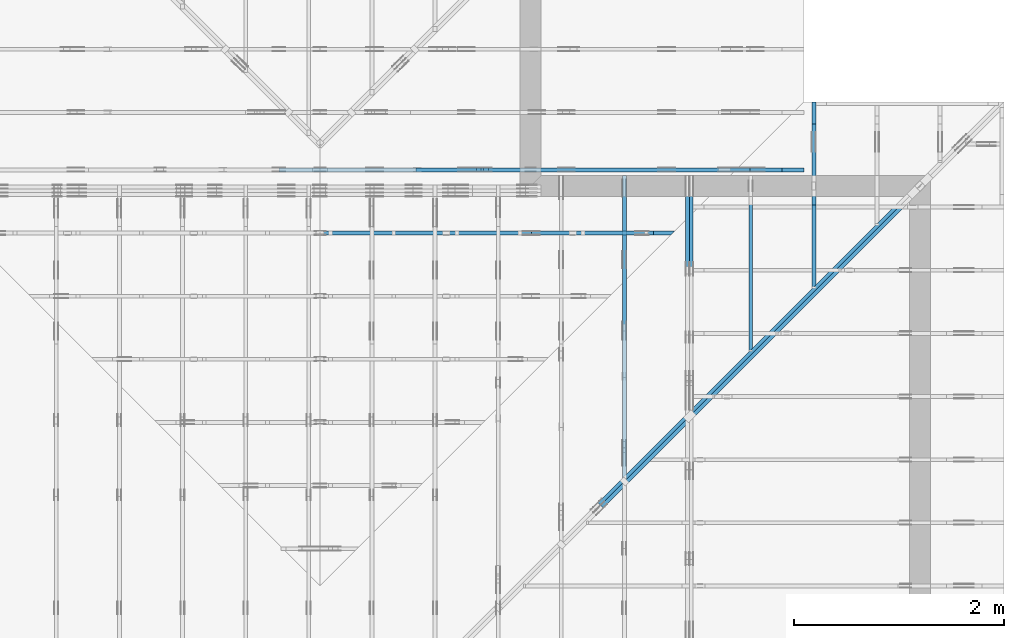
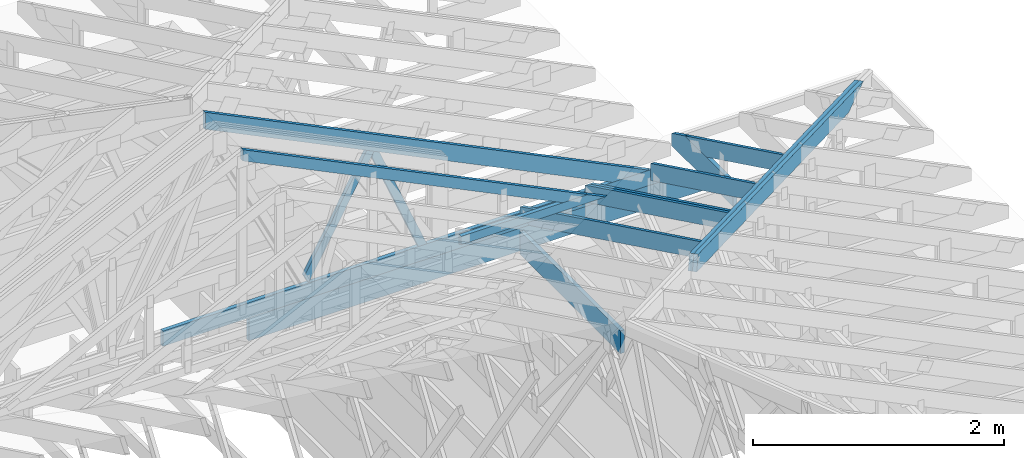
# One storey, part 37 of 159: 16 members, 7 elements without a shape of their own.
"""IFC2X3 building model written with IfcOpenShell, lengths in millimetres."""

from ifc_helpers import new_model, si_unit, frame, origin, origin_with_axes, origin_2d, place, context, project, spatial, faceted_brep, element, aggregate, save


model = new_model("IFC2X3")

# Units and contexts
model_context = context("Model", 3, precision=1e-05, world=origin())
plan_context = context("Plan", 2, precision=1e-05, world=origin_2d())
ifc_project = project(units=[si_unit("LENGTHUNIT", "METRE", prefix="MILLI"), si_unit("AREAUNIT", "SQUARE_METRE"), si_unit("VOLUMEUNIT", "CUBIC_METRE"), si_unit("SOLIDANGLEUNIT", "STERADIAN"), si_unit("PLANEANGLEUNIT", "RADIAN"), si_unit("MASSUNIT", "GRAM"), si_unit("TIMEUNIT", "SECOND"), si_unit("THERMODYNAMICTEMPERATUREUNIT", "DEGREE_CELSIUS"), si_unit("LUMINOUSINTENSITYUNIT", "LUMEN")], contexts=[model_context, plan_context])

# Site, building, storey
site_placement = place(None, origin_with_axes())
site = spatial("IfcSite", under=ifc_project, at=site_placement, CompositionType="ELEMENT")
building_placement = place(site_placement, origin_with_axes())
building = spatial("IfcBuilding", under=site, at=building_placement, Name="Plan 1", CompositionType="ELEMENT")
storey_placement = place(building_placement, origin_with_axes())
storey = spatial("IfcBuildingStorey", under=building, at=storey_placement, Name="Etasje 1", CompositionType="ELEMENT", Elevation=0.0)

# Assembly, members
assembly_1_placement = place(storey_placement, frame((10000.012663278096, 9072.000080051337, 1.1021457184401395e-15), z_axis=(9.811600543477555e-09, 1.0, 6.123031769111886e-17), x_axis=(-1.0, 9.811600543477555e-09, 0.0)))
assembly_1 = element("IfcElementAssembly", 1, at=assembly_1_placement, inside=storey, Name="T9 (79)", AssemblyPlace="FACTORY", PredefinedType="TRUSS")
member_1_placement = place(assembly_1_placement, frame((-8620.49494055916, 237.9781671363985, -36.0), z_axis=(0.0, 0.0, 1.0), x_axis=(0.8987940462991671, 0.438371146789077, 0.0)))
member_1 = element("IfcMember", 2, at=member_1_placement, Name="T9-O15", context=model_context, shape_type="Brep", body=[
    faceted_brep([(4545.394968070983, 148.0001484961972, 36.0), (0.0, 148.0001484961972, 36.0), (303.44568486758726, 0.0, 36.0), (4473.210566061087, 0.0, 36.0), (0.0, 148.0001484961972, 0.0), (4545.394968070983, 148.0001484961972, 5.566319558531987e-13), (4473.210566061087, 0.0, 5.4779220811838e-13), (303.44568486758726, 0.0, 3.7160151372883014e-14), (303.4453196677959, 0.00017811983983051505, -1.5777218104420236e-30), (303.4453196677959, 0.00017811983983051505, 36.0), (0.0003511150507478078, 148.00017811935547, 36.0), (0.0003511150507478078, 148.00017811935547, 1.5777218104420236e-30), (4473.210581428997, 0.00022326208287357807, 7.456776739153058e-29), (4473.210581428997, 0.00022326208287578236, 36.0), (303.44531966779596, 0.00017811983972168514, 36.0), (303.44531966779596, 0.00017811983971948085, 5.058390299724006e-30), (4545.395004536394, 148.00022326136218, 4.3937112682751334e-29), (4545.395004536394, 148.00022326136218, 36.0), (4473.210581428998, 0.000223262083636655, 36.0), (4473.210581428998, 0.000223262083636655, 4.444452615829284e-29), (0.0003511150507620187, 148.0001781193555, 0.0), (0.0003511150507620187, 148.0001781193555, 36.0), (4545.395004536393, 148.0002232613632, 36.0), (4545.395004536393, 148.0002232613632, 2.0510383535746307e-29)], [[[0, 1, 2, 3]], [[4, 5, 6, 7]], [[8, 9, 10, 11]], [[12, 13, 14, 15]], [[16, 17, 18, 19]], [[20, 21, 22, 23]]]),
])
member_2_placement = place(assembly_1_placement, frame((-4208.8187043163925, 371.0000000000005, -36.0), z_axis=(0.0, 0.0, 1.0), x_axis=(-1.0, 1.2246063538223773e-16, 0.0)))
member_2 = element("IfcMember", 3, at=member_2_placement, Name="T9-U34", context=model_context, shape_type="Brep", body=[
    faceted_brep([(4779.9996550586075, 148.0000000000011, 36.0), (0.0001433398574590683, 148.0000000000011, 36.0), (0.0001433398574590683, 5.115907697472721e-13, 36.0), (4476.5553191211075, 5.115907697472721e-13, 36.0), (0.0001433398574590683, 148.0000000000011, 1.755349002003689e-20), (4779.9996550586075, 148.0000000000011, 5.853617948853542e-13), (4476.5553191211075, 5.115907697472721e-13, 5.482018087033068e-13), (0.0001433398574590683, 5.115907697472721e-13, 1.755349002003689e-20), (0.0, 0.0, 0.0), (2.204291436880279e-15, -2.6993892992798474e-31, 36.0), (2.0328465473451462e-14, 148.0, 36.0), (1.8124174036571183e-14, 148.0, -1.1097489341483817e-30), (4476.555031444877, -8.223026602114393e-13, 1.1648012443743423e-28), (4476.555031444877, -8.20098368774559e-13, 36.0), (4.049083948919771e-31, 2.204291436880279e-15, 36.0), (0.0, 0.0, 0.0), (4780.0, 148.00000000000182, -5.048709793414475e-29), (4780.0, 148.00000000000182, 36.0), (4476.555031444878, 1.8189894035458565e-12, 36.0), (4476.555031444878, 1.8189894035458565e-12, -2.5243548967072372e-29), (0.0, 148.0, 0.0), (0.0, 148.0, 36.0), (4780.0, 148.00000000000077, 36.0), (4780.0, 148.00000000000077, -2.0510383535746307e-29)], [[[0, 1, 2, 3]], [[4, 5, 6, 7]], [[8, 9, 10, 11]], [[12, 13, 14, 15]], [[16, 17, 18, 19]], [[20, 21, 22, 23]]]),
])
member_3_placement = place(assembly_1_placement, frame((-9200.0, -4.4526871079142686e-10, -36.0), z_axis=(0.0, 0.0, 1.0), x_axis=(1.0, 1.060163597122437e-13, 0.0)))
member_3 = element("IfcMember", 4, at=member_3_placement, Name="T9-KI1", context=model_context, shape_type="Brep", body=[
    faceted_brep([(4200.000000000024, 223.0, 36.0), (211.18164062502365, 223.0, 36.0), (1.2732925824820995e-11, 120.00000000044527, 36.0), (0.0, 3.412120026781239e-24, 36.0), (4200.0, 3.412120026781239e-24, 36.0), (211.18164062502365, 223.00000000042286, 2.5861437892003784e-14), (4200.000000000024, 223.00000000042286, 5.143346686054014e-13), (4200.0, 3.412120026781239e-24, 5.143346686053984e-13), (0.0, 3.412120026781239e-24, 0.0), (1.2732925824820995e-11, 120.00000000044527, 1.5592821867824825e-27), (211.18129568312906, 223.0000000004229, 0.0), (211.18129568312906, 223.00000000042286, 36.0), (4200.000000000031, 223.00000000000014, 36.0), (4200.000000000031, 223.00000000000014, 9.466330862652142e-30), (2.1820767415192677e-11, 120.00000000024193, 1.5777218104420236e-30), (2.1820767415192677e-11, 120.00000000024193, 36.0), (211.18129568312906, 223.00000000042286, 36.0), (211.18129568312906, 223.00000000042286, 7.888609052210118e-31), (2.1827872842550333e-11, 4.452687107914246e-10, -3.407957865237955e-42), (2.1830077133987213e-11, 4.452687107914246e-10, 36.0), (2.1844772410233056e-11, 120.00000000024191, 36.0), (2.1842568118796175e-11, 120.00000000024191, -8.997964330950761e-31), (4200.000000000032, 5.856346223928665e-13, -3.585859398003264e-29), (4200.000000000032, 5.878389138297468e-13, 36.0), (2.1827872842550278e-11, 4.4527091508286147e-10, 36.0), (2.1827872842550278e-11, 4.452687107914246e-10, 0.0), (4200.000000000032, 223.0, 5.048709793414476e-29), (4200.000000000032, 223.0, 36.0), (4200.000000000032, 0.0, 36.0), (4200.000000000032, 0.0, 0.0)], [[[0, 1, 2, 3, 4]], [[5, 6, 7, 8, 9]], [[10, 11, 12, 13]], [[14, 15, 16, 17]], [[18, 19, 20, 21]], [[22, 23, 24, 25]], [[26, 27, 28, 29]]]),
])
member_4_placement = place(assembly_1_placement, frame((-6152.796875, 1441.5552978515625, -36.0), z_axis=(0.0, 0.0, 1.0), x_axis=(0.4904855667797226, -0.8714493150957056, 0.0)))
member_4 = element("IfcMember", 5, at=member_4_placement, Name="T9-D44", context=model_context, shape_type="Brep", body=[
    faceted_brep([(1178.2632781448474, 73.00020377135115, 36.0), (4.301953248464088, 73.00020377135115, 36.0), (0.0, 0.0, 36.0), (1228.4769030448888, 0.0, 36.0), (4.301953248464088, 73.00020377135115, 5.268199281915937e-16), (1178.2632781448474, 73.00020377135115, 1.442908696891763e-13), (1228.4769030448888, 0.0, 1.5044006209928072e-13), (0.0, 0.0, 0.0), (0.00011409658236583004, 0.00014858457780060855, -4.084990792550091e-32), (0.00011409658236803051, 0.00014858457780047888, 36.0), (4.301954951961308, 73.0001485845778, 36.0), (4.3019549519613065, 73.0001485845778, 1.7455877166075467e-32), (1228.4769202126026, 0.00014858457866609426, 5.838573987765892e-29), (1228.4769202126026, 0.00014858457866829855, 36.0), (0.00011409658236516408, 0.00014858457780285203, 36.0), (0.00011409658236516408, 0.00014858457780064774, 6.018531076210112e-36), (1178.2632427841645, 73.00014858458042, -3.7446940086186324e-30), (1178.2632427841645, 73.00014858458042, 36.0), (1228.4769202126026, 0.0001485845795059504, 36.0), (1228.4769202126026, 0.0001485845795059504, -4.290749435403667e-30), (4.3019549519613065, 73.0001485845778, 0.0), (4.3019549519613065, 73.0001485845778, 36.0), (1178.2632427841645, 73.00014858458059, 36.0), (1178.2632427841645, 73.00014858458059, 3.944304526105059e-30)], [[[0, 1, 2, 3]], [[4, 5, 6, 7]], [[8, 9, 10, 11]], [[12, 13, 14, 15]], [[16, 17, 18, 19]], [[20, 21, 22, 23]]]),
])
member_5_placement = place(assembly_1_placement, frame((-6186.465117591404, 1455.6510413266035, -36.0), z_axis=(0.0, 0.0, 1.0), x_axis=(-0.38618493241761287, -0.9224213776651123, 0.0)))
member_5 = element("IfcMember", 6, at=member_5_placement, Name="T9-D45", context=model_context, shape_type="Brep", body=[
    faceted_brep([(1145.3111634823956, 73.00010353965172, 36.0), (28.42489473033379, 73.00010353965172, 36.0), (4.7125680112003465e-05, 36.499870456011195, 36.0), (41.572369981045085, 0.00022683014503854793, 36.0), (1175.8737032657857, 0.00022683014503854793, 36.0), (28.42489473033379, 73.00010353965172, 3.4809306693498968e-15), (1145.3111634823956, 73.00010353965172, 1.402555327904241e-13), (1175.8737032657857, 0.00022683014503854793, 1.4399824083119298e-13), (41.572369981045085, 0.00022683014503854793, 5.090978842224247e-15), (4.7125680112003465e-05, 36.499870456011195, 5.771040729336028e-21), (0.0, 36.50005176948798, 0.0), (0.0, 36.50005176948798, 36.0), (28.424887900124535, 73.00005176983177, 36.0), (28.424887900124535, 73.00005176983177, -1.9721522630525295e-31), (41.572419421671604, 5.176983176724548e-05, 5.9164567891575885e-31), (41.572419421671604, 5.176983176724548e-05, 36.0), (1.0658141036401503e-14, 36.500051769487996, 36.0), (1.0658141036401503e-14, 36.500051769487996, -9.860761315262648e-31), (1175.873681591602, 5.1769836610062956e-05, -1.7866471045831624e-29), (1175.873681591602, 5.176983661226725e-05, 36.0), (41.57241942167161, 5.176983178331862e-05, 36.0), (41.57241942167161, 5.176983178111433e-05, -6.316598827759418e-31), (1145.3111851565714, 73.00005176983541, 1.262177448353619e-29), (1145.3111851565714, 73.00005176983541, 36.0), (1175.873681591602, 5.17698363182717e-05, 36.0), (1175.873681591602, 5.17698363182717e-05, 0.0), (28.42488790012453, 73.00005176983177, -7.888609052210118e-31), (28.42488790012453, 73.00005176983176, 36.0), (1145.3111851565711, 73.00005176983541, 36.0), (1145.3111851565711, 73.00005176983541, 7.888609052210118e-31)], [[[0, 1, 2, 3, 4]], [[5, 6, 7, 8, 9]], [[10, 11, 12, 13]], [[14, 15, 16, 17]], [[18, 19, 20, 21]], [[22, 23, 24, 25]], [[26, 27, 28, 29]]]),
])
aggregate(assembly_1, [member_1, member_2, member_3, member_4, member_5])

assembly_2_placement = place(storey_placement, frame((18074.541652722903, -699.9989301294845, 4.408582873760558e-15), z_axis=(-1.0, 1.836909530733566e-16, 6.123031769111886e-17), x_axis=(-1.836909530733566e-16, -1.0, 0.0)))
assembly_2 = element("IfcElementAssembly", 7, at=assembly_2_placement, inside=storey, Name="V5 (30)", AssemblyPlace="FACTORY", PredefinedType="TRUSS")
member_6_placement = place(assembly_2_placement, frame((-9699.99900534675, 296.7476881192001, -36.00000332975768), z_axis=(0.0, 0.0, 1.0), x_axis=(0.898794046299167, 0.4383711467890773, 0.0)))
member_6 = element("IfcMember", 8, at=member_6_placement, Name="V5-O45.1", context=model_context, shape_type="Brep", body=[
    faceted_brep([(2602.8636231750697, 147.9999948154009, 36.000006365669606), (2530.6791992187505, 1.2483951650210656e-09, 36.00000332975742), (2490.625529273321, 3.2665303706380655e-07, 3.1153990676102694e-06), (2562.809953229639, 147.99999514080525, 6.15131102676969e-06), (72.18442310739556, 148.0000000005275, 3.3297576820245922e-06), (72.18442310739556, 148.0000000005275, 36.00000332975768), (2602.8636223261456, 148.00000000052734, 36.00000332975768), (2562.8099533503155, 148.00000000052734, 3.3297576820245922e-06), (72.18446417931773, 148.00000000095315, 3.3297576908643475e-06), (2562.8099524605677, 148.00000000095315, 3.329757995867927e-06), (2490.625527106564, 5.338733899407089e-10, 3.3297579870281766e-06), (0.00013800744272884913, 5.338733899407089e-10, 3.329757682024609e-06), (9.074371155293194e-05, 4.256808097125099e-07, 1.9345578721186025e-06), (9.074371217997383e-05, 4.256805038837426e-07, 36.00000332975768), (72.18451603777797, 148.00000490829916, 36.000003024692596), (72.18451603777734, 148.00000490829947, 1.4904773958135757e-26), (2530.6791983289895, 1.2282646835130028e-09, 36.00000332975768), (4.107190943614114e-05, 1.2287295463793223e-09, 36.00000332975768), (4.107190943614114e-05, 1.2287273420878854e-09, 3.3297576820245922e-06), (2490.6255293531594, 1.2282698367181943e-09, 3.3297576820245922e-06), (2602.863624572754, 148.00000000124874, 36.00000332975768), (72.1845703125, 148.00000000124874, 36.00000332975768), (0.0, 0.0, 36.00000332975768), (2530.67919921875, 0.0, 36.00000332975768)], [[[0, 1, 2, 3]], [[4, 5, 6, 7]], [[8, 9, 10, 11]], [[12, 13, 14, 15]], [[16, 17, 18, 19]], [[20, 21, 22, 23]]]),
])
member_7_placement = place(assembly_2_placement, frame((-9699.998968431562, 296.74770612394013, -72.00000332975767), z_axis=(0.0, 0.0, 1.0), x_axis=(0.898794046299167, 0.4383711467890773, 0.0)))
member_7 = element("IfcMember", 9, at=member_7_placement, Name="V5-O45.1", context=model_context, shape_type="Brep", body=[
    faceted_brep([(2562.8099122323115, 147.99999481794435, 36.00000635984384), (2490.6254882812495, 1.2288410289329477e-09, 36.000003329758556), (2450.5718183387285, 3.223752287340176e-07, 3.1121621759666596e-06), (2522.756242289791, 147.99999513909034, 6.1422481394401984e-06), (72.18442310740829, 148.00000000053387, 3.329757674919165e-06), (72.18442310740829, 148.00000000053387, 36.000003329757675), (2562.8099113886583, 148.0000000005337, 36.000003329757675), (2522.756242412828, 148.00000000053373, 3.329757674919165e-06), (72.184464187907, 148.00000000095315, 3.32975768375892e-06), (2522.756241531657, 148.00000000095315, 3.3297579838574972e-06), (2450.571816177653, 5.411493475548923e-10, 3.3297579750177466e-06), (0.00013801603199681267, 5.411493475548923e-10, 3.329757674919182e-06), (4.967180211679079e-05, 4.256808097125031e-07, 1.934557872118603e-06), (4.967180274383268e-05, 4.2568050388373923e-07, 36.000003329757675), (72.18447496586853, 148.0000049082992, 36.00000302469259), (72.1844749658679, 148.0000049082995, 1.489287498516035e-26), (2490.625487400066, 1.2082613812213293e-09, 36.000003329757675), (4.108048597117886e-05, 1.2087188865833127e-09, 36.000003329757675), (4.108048597117886e-05, 1.209627953350488e-09, 3.329757674919165e-06), (2450.571818424236, 1.2091778054851332e-09, 3.329757674919165e-06), (2562.809913635253, 148.00000000122873, 36.000003329757675), (72.1845703125, 148.00000000122873, 36.000003329757675), (0.0, 0.0, 36.000003329757675), (2490.62548828125, 0.0, 36.000003329757675)], [[[0, 1, 2, 3]], [[4, 5, 6, 7]], [[8, 9, 10, 11]], [[12, 13, 14, 15]], [[16, 17, 18, 19]], [[20, 21, 22, 23]]]),
])
aggregate(assembly_2, [member_6, member_7])

assembly_3_placement = place(storey_placement, frame((17475.02226140475, -699.9989301294827, 1.1021457184401395e-15), z_axis=(-1.0, 1.836909530733566e-16, 6.123031769111886e-17), x_axis=(-1.836909530733566e-16, -1.0, 0.0)))
assembly_3 = element("IfcElementAssembly", 10, at=assembly_3_placement, inside=storey, Name="V6 (31)", AssemblyPlace="FACTORY", PredefinedType="TRUSS")
member_8_placement = place(assembly_3_placement, frame((-9670.743151488241, 311.0167214529156, -36.00000021372108), z_axis=(0.0, 0.0, 1.0), x_axis=(0.898794046299167, 0.4383711467890773, 0.0)))
member_8 = element("IfcMember", 11, at=member_8_placement, Name="V6-O35", context=model_context, shape_type="Brep", body=[
    faceted_brep([(3237.3399415355216, 147.99999481389875, 36.00000325085716), (3165.155517578125, 2.725073500187136e-10, 36.00000021372034), (3125.1018476321215, 3.2654645565344254e-07, -6.821210263296962e-13), (3197.286271589518, 147.99999514017327, 3.0371359116543317e-06), (39.63437428008547, 148.000000001226, 2.1372107994466205e-07), (39.63437428008547, 148.000000001226, 36.00000021372108), (3237.3399406863364, 148.0000000012258, 36.00000021372108), (3197.286271710507, 148.0000000012258, 2.1372107994466205e-07), (39.63441535027778, 148.00000000006548, 2.1372108479831773e-07), (3197.286270819026, 148.00000000006548, 2.1372147148637026e-07), (3125.101845465023, 1.2114469427615404e-09, 2.1372146264661968e-07), (136.83216925652778, 1.2114469427615404e-09, 2.1372109670121643e-07), (0.00013800652595818974, 66.73750305296926, 2.1372107994467894e-07), (2.4363136603255953e-05, 66.73749994131505, 9.839211685402915e-07), (2.436313769038634e-05, 66.73749994131452, 36.00000021372108), (39.634392709069246, 147.99999761954862, 36.00000003080295), (39.634392709068166, 147.99999761954916, 2.917744950536871e-06), (136.83217745155704, -1.0658141036401503e-13, 2.1372107994466205e-07), (136.83217745155704, -1.0658141036401503e-13, 36.00000021372108), (2.7481415610708382e-05, 66.73749870396935, 36.00000021372108), (2.7481415610708382e-05, 66.73749870396935, 2.1372107994466205e-07), (3165.15551668665, 2.695407202845241e-10, 36.00000021372108), (136.83207232019595, 2.7009699590423417e-10, 36.00000021372108), (136.83207232019595, 2.700947916127973e-10, 2.1372107994466205e-07), (3125.10184771082, 2.695458734897155e-10, 2.1372107994466205e-07), (3237.339942932129, 148.00000000027376, 36.00000021372108), (39.63427734374818, 148.00000000027376, 36.00000021372108), (0.0, 66.73750305203157, 36.00000021372108), (136.832275390625, 0.0, 36.00000021372108), (3165.155517578124, 0.0, 36.00000021372108)], [[[0, 1, 2, 3]], [[4, 5, 6, 7]], [[8, 9, 10, 11, 12]], [[13, 14, 15, 16]], [[17, 18, 19, 20]], [[21, 22, 23, 24]], [[25, 26, 27, 28, 29]]]),
])
member_9_placement = place(assembly_3_placement, frame((-8099.99999999999, 223.0, -36.0), z_axis=(0.0, 0.0, 1.0), x_axis=(-1.0, 1.2246063538223773e-16, 0.0)))
member_9 = element("IfcMember", 12, at=member_9_placement, Name="V6-U16", context=model_context, shape_type="Brep", body=[
    faceted_brep([(1599.99902343751, 223.00000000001475, 36.0), (1.000444171950221e-11, 223.00000000001475, 36.0), (1.000444171950221e-11, 0.0, 36.0), (1599.99902343751, 0.0, 36.0), (1.000444171950221e-11, 223.00000000001475, 1.2251502896148076e-27), (1599.99902343751, 223.00000000001475, 1.9593689702111736e-13), (1599.99902343751, 0.0, 1.9593689702111736e-13), (1.000444171950221e-11, 0.0, 1.2251502896148076e-27), (0.0, 0.0, 0.0), (2.204291436880279e-15, -2.6993892992798474e-31, 36.0), (2.951301312711929e-14, 223.0, 36.0), (2.7308721690239013e-14, 223.0, -1.6721217048316832e-30), (1599.998923973918, -2.93905327261114e-13, 3.0177808643548415e-29), (1599.998923973918, -2.917010358242337e-13, 36.0), (4.049083948919771e-31, 2.204291436880279e-15, 36.0), (0.0, 0.0, 0.0), (1599.998923973918, 223.00000000001475, 0.0), (1599.998923973918, 223.00000000001475, 36.0), (1599.998923973918, 1.9895196601282805e-13, 36.0), (1599.998923973918, 1.9895196601282805e-13, 0.0), (0.0, 223.0, 0.0), (0.0, 223.0, 36.0), (1599.998923973918, 223.00000000001518, 36.0), (1599.998923973918, 223.00000000001518, 2.68212707775144e-29)], [[[0, 1, 2, 3]], [[4, 5, 6, 7]], [[8, 9, 10, 11]], [[12, 13, 14, 15]], [[16, 17, 18, 19]], [[20, 21, 22, 23]]]),
])
aggregate(assembly_3, [member_8, member_9])

assembly_4_placement = place(storey_placement, frame((19275.02226140475, 9699.999999999993, 1.1021457184401395e-15), z_axis=(-1.0, 1.836909530733566e-16, 6.123031769111886e-17), x_axis=(-1.836909530733566e-16, -1.0, 0.0)))
assembly_4 = element("IfcElementAssembly", 13, at=assembly_4_placement, inside=storey, Name="S23 (56)", AssemblyPlace="FACTORY", PredefinedType="TRUSS")
member_10_placement = place(assembly_4_placement, frame((276.0602225692094, 89.97847976247769, -36.0000002174581), z_axis=(0.0, 0.0, 1.0), x_axis=(0.898794046299167, 0.4383711467890774, 0.0)))
member_10 = element("IfcMember", 14, at=member_10_placement, Name="S23-O60", context=model_context, shape_type="Brep", body=[
    faceted_brep([(1738.8827037750734, 147.9999948173006, 36.00000324787811), (1666.6982798237927, 6.917844075360335e-10, 36.00000021745757), (1626.6446098811475, 3.220388293811993e-07, -5.684341886080801e-13), (1698.829033832429, 147.99999513864776, 3.0304200890896027e-06), (1.2501499782047176e-05, 147.9999999999706, 2.1745810130369136e-07), (1.2501499782047176e-05, 147.9999999999706, 36.0000002174581), (1738.8827029311874, 147.9999999999705, 36.0000002174581), (1698.8290339553573, 147.9999999999705, 2.1745810130369136e-07), (5.358157699220101e-05, 148.00000000125226, 2.1745810130369793e-07), (1698.8290330737645, 148.00000000125226, 2.1745830934337416e-07), (1626.6446077197606, 0.0, 2.1745830050362357e-07), (303.44499987063966, 0.0, 2.1745813846375886e-07), (303.4449717131313, 2.8764191029040376e-10, 2.1745810130369136e-07), (303.4449717131313, 2.8764191029040376e-10, 36.0000002174581), (7.105427357601002e-15, 148.0000015412279, 36.0000002174581), (7.105427357601002e-15, 148.0000015412279, 2.1745810130369136e-07), (1666.6982789421786, 6.79733994223045e-10, 36.0000002174581), (303.4450250054109, 6.79984411512541e-10, 36.0000002174581), (303.4450250054109, 6.798702967402219e-10, 2.1745810130369136e-07), (1626.6446099663485, 6.796272369473541e-10, 2.1745810130369136e-07), (1738.8827051777957, 148.000000000692, 36.0000002174581), (3.7636291722265014e-05, 148.000000000692, 36.0000002174581), (303.4449839253542, 2.878266514017014e-10, 36.0000002174581), (1666.6982798237918, 2.878266514017014e-10, 36.0000002174581)], [[[0, 1, 2, 3]], [[4, 5, 6, 7]], [[8, 9, 10, 11]], [[12, 13, 14, 15]], [[16, 17, 18, 19]], [[20, 21, 22, 23]]]),
])
member_11_placement = place(assembly_4_placement, frame((982.00634765625, 223.00000000000057, -36.0), z_axis=(0.0, 0.0, 1.0), x_axis=(-1.0, -7.657177843178875e-16, 0.0)))
member_11 = element("IfcMember", 15, at=member_11_placement, Name="S23-U21", context=model_context, shape_type="Brep", body=[
    faceted_brep([(982.0063476562502, 223.00000000001438, 36.0), (2.2737367544323206e-13, 223.00000000001438, 36.0), (0.0, 5.684341886080801e-13, 36.0), (770.8250579833984, 5.684341886080801e-13, 36.0), (982.0063188939531, 102.99998474121077, 36.0), (2.2737367544323206e-13, 223.00000000001438, 2.78443247639729e-29), (982.0063476562502, 223.00000000001438, 1.2025712128337504e-13), (982.0063188939531, 102.99998474121077, 1.2025711776112586e-13), (770.8250579833984, 5.684341886080801e-13, 9.439572636919721e-14), (0.0, 5.684341886080801e-13, 0.0), (1.6105506801977754e-05, 5.684341886080801e-13, 0.0), (1.6105506804182045e-05, 5.684341886080801e-13, 36.0), (1.6105507029554554e-05, 223.00000000000057, 36.0), (1.6105507027350263e-05, 223.00000000000057, 1.225320264969462e-31), (770.8250519745052, -2.5778956449313753e-13, 1.5784536931369985e-29), (770.8250519745052, -2.5558527305625725e-13, 36.0), (1.6105506801977754e-05, 5.706384746587427e-13, 36.0), (1.6105506801977754e-05, 5.684341832218624e-13, 3.2979982550020796e-37), (982.0063188939536, 102.99998597132787, -6.310887241768095e-30), (982.0063188939536, 102.99998597132787, 36.0), (770.8250519745051, 5.684341886080802e-14, 36.0), (770.8250519745051, 5.684341886080802e-14, -3.1554436208840472e-30), (982.0062942062657, 223.00000000001438, -3.2727595310987586e-21), (982.0062942062657, 223.00000000001438, 36.0), (982.0062942062657, 102.99998597132782, 36.0), (982.0062942062657, 102.99998597132782, -1.5116349817962461e-21), (1.610550702935143e-05, 223.00000000000057, 0.0), (1.610550702935143e-05, 223.00000000000057, 36.0), (982.0063476562502, 223.00000000001447, 36.0), (982.0063476562502, 223.00000000001447, 4.733165431326071e-30)], [[[0, 1, 2, 3, 4]], [[5, 6, 7, 8, 9]], [[10, 11, 12, 13]], [[14, 15, 16, 17]], [[18, 19, 20, 21]], [[22, 23, 24, 25]], [[26, 27, 28, 29]]]),
])
aggregate(assembly_4, [member_10, member_11])

# Assembly, member
assembly_5_placement = place(storey_placement, frame((18675.02226140475, 8999.999999999993, 1.1021457184401395e-15), z_axis=(-1.0, 1.836909530733566e-16, 6.123031769111886e-17), x_axis=(-1.836909530733566e-16, -1.0, 0.0)))
assembly_5 = element("IfcElementAssembly", 16, at=assembly_5_placement, inside=storey, Name="S25 (55)", AssemblyPlace="FACTORY", PredefinedType="TRUSS")
member_12_placement = place(assembly_5_placement, frame((-2.414098253211705e-05, 296.7477130310035, -36.000003329369015), z_axis=(0.0, 0.0, 1.0), x_axis=(0.898794046299167, 0.4383711467890774, 0.0)))
member_12 = element("IfcMember", 17, at=member_12_placement, Name="S25-O57", context=model_context, shape_type="Brep", body=[
    faceted_brep([(1934.7676759040228, 147.99999481679572, 36.00000635936294), (1862.5832519531255, -2.2737367544323206e-13, 36.00000332936861), (1822.5295820106937, 3.2103554303830606e-07, 3.1116738909986452e-06), (1894.7140059615908, 147.99999513783155, 6.141668109194143e-06), (72.1844231082124, 148.0000000009528, 3.3293690151481314e-06), (72.1844231082124, 148.0000000009527, 36.000003329369015), (1934.7676750613375, 148.00000000095258, 36.000003329369015), (1894.7140060855074, 148.0000000009527, 3.3293690151481314e-06), (72.18446418889937, 148.000000000665, 3.3293690239878867e-06), (1894.714005204525, 148.000000000665, 3.3293692471760124e-06), (1822.529579850521, 9.463292371947318e-10, 3.3293692383362618e-06), (1.5946712153436238e-05, 9.463292371947318e-10, 3.3293690151481336e-06), (2.7067635954836085e-05, 4.2714373194030486e-07, 1.934169205242142e-06), (2.706763595681729e-05, 4.271437309740063e-07, 36.000003329369015), (72.18445236166475, 148.00000490968523, 36.00000302469259), (72.18445236166475, 148.00000490968523, -1.486125785993182e-30), (1862.5832510721605, 2.932611199490172e-11, 36.000003329369015), (4.108070496045002e-05, 2.966825167992348e-11, 36.000003329369015), (4.108070496045002e-05, 2.978595147514612e-11, 3.3293690151481314e-06), (1822.5295820963302, 2.945116928675261e-11, 3.3293690151481314e-06), (1934.7676773071291, 148.0, 36.000003329369015), (72.18444824218736, 148.0, 36.000003329369015), (0.0, 1.3864678294339683e-09, 36.000003329369015), (1862.5832519531252, 1.3864678294339683e-09, 36.000003329369015)], [[[0, 1, 2, 3]], [[4, 5, 6, 7]], [[8, 9, 10, 11]], [[12, 13, 14, 15]], [[16, 17, 18, 19]], [[20, 21, 22, 23]]]),
])
aggregate(assembly_5, [member_12])

# Assembly, members
assembly_6_placement = place(storey_placement, frame((21074.556818978763, 9725.45584412271, 2.204291436880279e-15), z_axis=(-0.7071067811865471, 0.7071067811865479, 6.123031769111886e-17), x_axis=(-0.7071067811865479, -0.7071067811865471, 0.0)))
assembly_6 = element("IfcElementAssembly", 18, at=assembly_6_placement, inside=storey, Name="GR1 (36)", AssemblyPlace="FACTORY", PredefinedType="TRUSS")
member_13_placement = place(assembly_6_placement, frame((382.90850618663825, 83.08701368323861, -36.00000195234117), z_axis=(0.0, 0.0, 1.0), x_axis=(0.9453579955214152, 0.32603413978252627, 0.0)))
member_13 = element("IfcMember", 19, at=member_13_placement, Name="GR1-O2", context=model_context, shape_type="Brep", body=[
    faceted_brep([(9.094947017729282e-13, 148.00000315181347, 1.952341179389805e-06), (9.094947017729282e-13, 148.00000315181347, 36.00000195234118), (5380.000000000001, 148.00000315181313, 36.00000195234118), (5380.000000000001, 148.00000315181313, 1.952341179389805e-06), (429.13598996492084, 3.151003625134763e-06, 1.952341179389805e-06), (429.13598996492084, 3.151003625134763e-06, 36.00000195234118), (6.069707794154056e-06, 148.00000105849915, 36.00000195234118), (6.069707794154056e-06, 148.00000105849915, 1.952341179389805e-06), (5379.999999999999, 3.1509182713895772e-06, 1.952341179389805e-06), (5379.999999999999, 3.1509182735938687e-06, 36.00000195234118), (429.1362304687506, 3.150919183022753e-06, 36.00000195234118), (429.1362304687506, 3.1509191808184616e-06, 1.952341179389805e-06), (5380.0, 148.00000277524896, 1.8783536717137395e-06), (5379.999999999999, 148.00000277524896, 36.00000195234118), (5379.999999999999, 0.0, 36.00000255341424), (5380.0, 0.0, 0.0), (5379.999999999999, 148.00000315091938, 36.00000195234118), (4.547473508864641e-13, 148.00000315091938, 36.00000195234118), (429.1362304687506, 3.151003227230831e-06, 36.00000195234118), (5379.999999999999, 3.151003227230831e-06, 36.00000195234118), (0.0, 148.0000031518136, 1.952341179389805e-06), (5379.999999999999, 148.0000031518136, 1.9523418382280232e-06), (5380.0, 3.150919837935362e-06, 1.9523418382280232e-06), (429.1362304687497, 3.150919837935362e-06, 1.9523412319421e-06)], [[[0, 1, 2, 3]], [[4, 5, 6, 7]], [[8, 9, 10, 11]], [[12, 13, 14, 15]], [[16, 17, 18, 19]], [[20, 21, 22, 23]]]),
])
member_14_placement = place(assembly_6_placement, frame((382.90850618663825, 83.08701368323861, -72.00000195234118), z_axis=(0.0, 0.0, 1.0), x_axis=(0.9453579955214152, 0.32603413978252627, 0.0)))
member_14 = element("IfcMember", 20, at=member_14_placement, Name="GR1-O2", context=model_context, shape_type="Brep", body=[
    faceted_brep([(9.094947017729282e-13, 148.00000315181347, 1.952341179389805e-06), (9.094947017729282e-13, 148.00000315181347, 36.00000195234118), (5380.000000000001, 148.00000315181313, 36.00000195234118), (5380.000000000001, 148.00000315181313, 1.952341179389805e-06), (429.13598996492084, 3.151003625134763e-06, 1.952341179389805e-06), (429.13598996492084, 3.151003625134763e-06, 36.00000195234118), (6.069707794154056e-06, 148.00000105849915, 36.00000195234118), (6.069707794154056e-06, 148.00000105849915, 1.952341179389805e-06), (5379.999999999999, 3.1509182713895772e-06, 1.952341179389805e-06), (5379.999999999999, 3.1509182735938687e-06, 36.00000195234118), (429.1362304687506, 3.150919183022753e-06, 36.00000195234118), (429.1362304687506, 3.1509191808184616e-06, 1.952341179389805e-06), (5380.0, 148.00000277524896, 1.8783536717137395e-06), (5379.999999999999, 148.00000277524896, 36.00000195234118), (5379.999999999999, 0.0, 36.00000255341424), (5380.0, 0.0, 0.0), (5379.999999999999, 148.00000315091938, 36.00000195234118), (4.547473508864641e-13, 148.00000315091938, 36.00000195234118), (429.1362304687506, 3.151003227230831e-06, 36.00000195234118), (5379.999999999999, 3.151003227230831e-06, 36.00000195234118), (0.0, 148.0000031518136, 1.952341179389805e-06), (5379.999999999999, 148.0000031518136, 1.9523418382280232e-06), (5380.0, 3.150919837935362e-06, 1.9523418382280232e-06), (429.1362304687497, 3.150919837935362e-06, 1.9523412319421e-06)], [[[0, 1, 2, 3]], [[4, 5, 6, 7]], [[8, 9, 10, 11]], [[12, 13, 14, 15]], [[16, 17, 18, 19]], [[20, 21, 22, 23]]]),
])
aggregate(assembly_6, [member_13, member_14])

assembly_7_placement = place(storey_placement, frame((11246.01259527543, 8436.00006782605, 727.7147722720857), z_axis=(0.0, -1.0, 6.123031769111886e-17), x_axis=(1.0, 0.0, 0.0)))
assembly_7 = element("IfcElementAssembly", 21, at=assembly_7_placement, inside=storey, Name="Tr1 (1)", AssemblyPlace="FACTORY", PredefinedType="TRUSS")
member_15_placement = place(assembly_7_placement, frame((3311.0396534901315, 1547.773339054303, -36.0), z_axis=(0.0, 0.0, 1.0), x_axis=(0.8987940462991671, -0.438371146789077, 0.0)))
member_15 = element("IfcMember", 22, at=member_15_placement, Name="Tr1-O81", context=model_context, shape_type="Brep", body=[
    faceted_brep([(3528.1389557490083, 97.99999699151886, 36.0), (0.0, 97.99999699151886, 36.0), (47.79775946143309, 1.1130960956506897e-05, 36.0), (3327.209333601738, 1.1130960956506897e-05, 36.0), (0.0, 97.99999699151886, 0.0), (3528.1389557490083, 97.99999699151886, 4.3205813823784825e-13), (3327.209333601738, 1.1130960956506897e-05, 4.074521690425806e-13), (47.79775946143309, 1.1130960956506897e-05, 5.853343993494461e-15), (47.79784035376406, -3.552713678800501e-15, -3.298634383251684e-31), (47.797840353764066, -3.552713678800501e-15, 36.0), (4.667482971854042e-05, 97.9999999989341, 36.0), (4.667482971854042e-05, 97.9999999989341, -1.454714347618945e-30), (3327.209194098851, 1.3972386767200252e-11, -4.8048262503642547e-29), (3327.209194098851, 1.3974591058637133e-11, 36.0), (47.79784035376406, 1.3477287146355053e-14, 36.0), (47.79784035376406, 1.1272995709474774e-14, -6.902491086217597e-31), (3528.1389705745246, 98.00000000045429, -8.5634643567728e-29), (3528.1389705745246, 98.00000000045429, 36.0), (3327.2091940988507, 1.4551915228366852e-11, 36.0), (3327.2091940988507, 1.4551915228366852e-11, -7.232398748809859e-29), (4.667482971854042e-05, 97.99999999893407, 0.0), (4.667482971854042e-05, 97.99999999893407, 36.0), (3528.138970574525, 98.00000000045287, 36.0), (3528.138970574525, 98.00000000045287, -3.1554436208840472e-30)], [[[0, 1, 2, 3]], [[4, 5, 6, 7]], [[8, 9, 10, 11]], [[12, 13, 14, 15]], [[16, 17, 18, 19]], [[20, 21, 22, 23]]]),
])
member_16_placement = place(assembly_7_placement, frame((6726.000154104084, 89.220829355236, -36.00000004574683), z_axis=(0.0, 0.0, 1.0), x_axis=(-1.0, 1.2246063538223773e-16, 0.0)))
member_16 = element("IfcMember", 23, at=member_16_placement, Name="Tr1-U51", context=model_context, shape_type="Brep", body=[
    faceted_brep([(7.888609052210118e-31, 98.00000032473731, 3.208145563604603e-05), (36.0, 80.44164257343391, 36.00000043078701), (1364.0001220703125, 80.44164257343384, 36.00000043078698), (1364.0001220703125, 98.00000032519554, 3.2080515950383415e-05), (1364.0001220703125, 80.44164276123047, 36.00000004574683), (36.0, 80.44164276123047, 36.00000004574683), (200.9298095703125, 0.0, 36.00000004574683), (1364.0001220703125, 0.0, 36.00000004574683), (200.92982310784106, 2.2043293625984006e-06, 4.574648215793786e-08), (200.929823107841, 2.2043293057549818e-06, 36.00000004574684), (36.000018451280084, 80.44164276123037, 36.00000004574684), (5.0101019034798355e-05, 98.00000051301302, 3.0563325033483586e-05), (1364.0001220703125, 3.25195321249733e-07, 4.5746830323878385e-08), (1364.0001220703125, 3.2519532345402443e-07, 36.00000004574683), (200.9298095703125, 3.251955370995186e-07, 36.00000004574683), (200.9298095703125, 3.251955348952272e-07, 4.5746830323878385e-08), (1364.0001220703125, 98.00000032519559, 3.208051598591055e-05), (1364.0001220703125, 80.44164335122939, 36.00000064271139), (1364.0001220703125, 1.7605030819822787e-06, 35.99999978393906), (1364.0001220703125, 1.7605030819822787e-06, 0.0), (0.0, 98.00000032473714, 4.5746830323878385e-08), (1364.0001220703125, 98.00000032473714, 4.5746997360199995e-08), (1364.0001220703125, 3.2519558601507015e-07, 4.5746997360199995e-08), (200.9298095703125, 3.2519558601507015e-07, 4.574685492987053e-08)], [[[0, 1, 2, 3]], [[4, 5, 6, 7]], [[8, 9, 10, 11]], [[12, 13, 14, 15]], [[16, 17, 18, 19]], [[20, 21, 22, 23]]]),
])
aggregate(assembly_7, [member_15, member_16])

save(model, "model.ifc")
